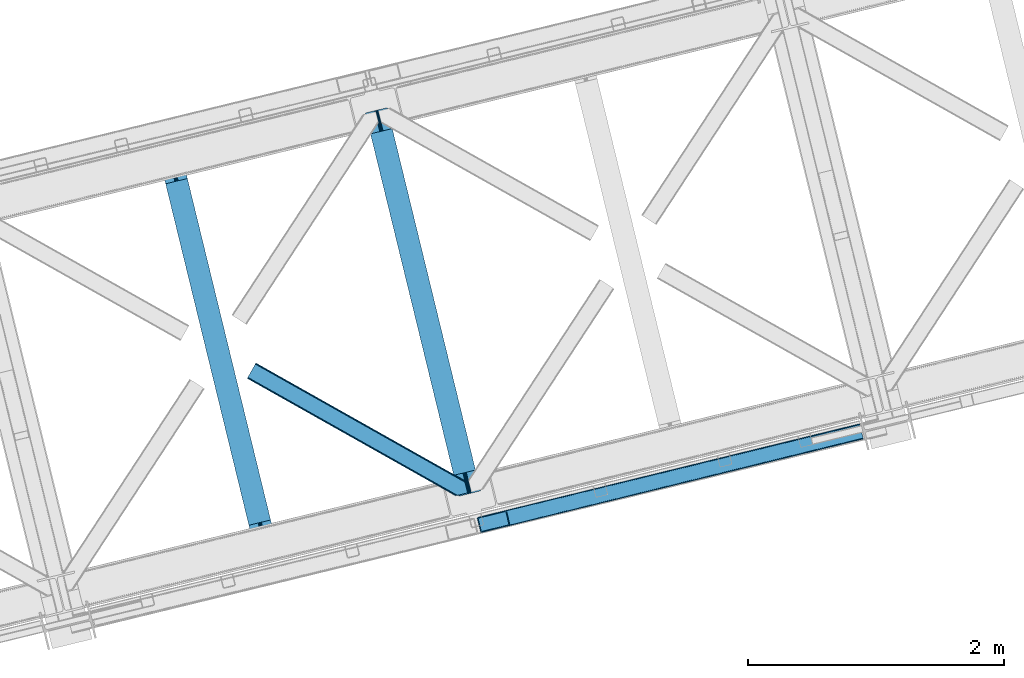
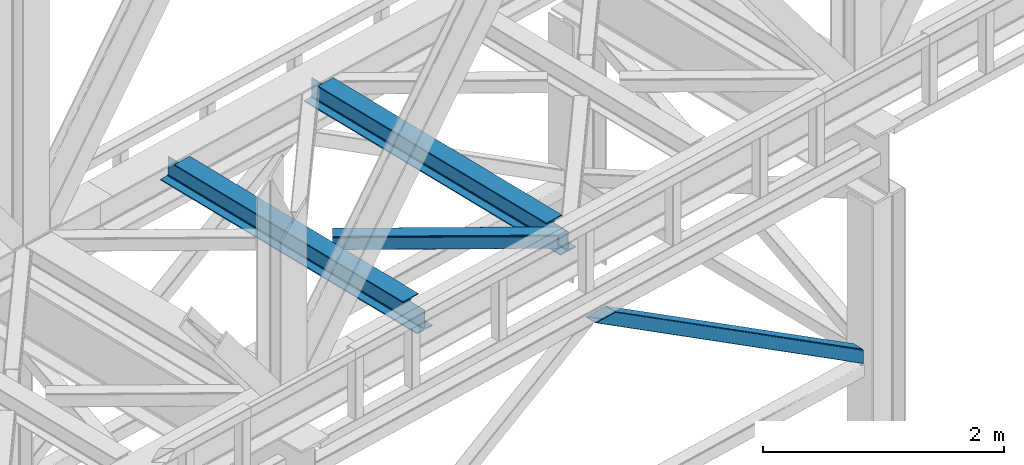
# One storey, part 47 of 92: 2 beams, 2 members.
"""IFC4 building model written with IfcOpenShell, lengths in millimetres."""

from ifc_helpers import new_model, entity, si_unit, converted_unit, derived_unit, direction, frame, origin, place, context, subcontext, project, spatial, triangles, polygons, material, type_object, element, save


model = new_model("IFC4")

# Units and contexts
model_context = context("Model", 3, precision=0.01, world=origin(), true_north=direction((6.12303176911189e-17, 1.0)))
plan_context = context("Plan", 3, precision=0.01, world=origin(), true_north=direction((6.12303176911189e-17, 1.0)))
body_context = subcontext(model_context, "Body", "Model", "MODEL_VIEW")
ifc_project = project(units=[si_unit("LENGTHUNIT", "METRE", prefix="MILLI"), si_unit("AREAUNIT", "SQUARE_METRE"), si_unit("VOLUMEUNIT", "CUBIC_METRE"), converted_unit("PLANEANGLEUNIT", "DEGREE", entity("IfcRatioMeasure", 0.0174532925199433), si_unit("PLANEANGLEUNIT", "RADIAN"), dimensions=[0, 0, 0, 0, 0, 0, 0]), si_unit("MASSUNIT", "GRAM", prefix="KILO"), derived_unit("MASSDENSITYUNIT", [(si_unit("MASSUNIT", "GRAM", prefix="KILO"), 1), (si_unit("LENGTHUNIT", "METRE"), -3)]), derived_unit("MOMENTOFINERTIAUNIT", [(si_unit("LENGTHUNIT", "METRE"), 4)]), si_unit("TIMEUNIT", "SECOND"), si_unit("FREQUENCYUNIT", "HERTZ"), si_unit("THERMODYNAMICTEMPERATUREUNIT", "DEGREE_CELSIUS"), derived_unit("THERMALTRANSMITTANCEUNIT", [(si_unit("MASSUNIT", "GRAM", prefix="KILO"), 1), (si_unit("THERMODYNAMICTEMPERATUREUNIT", "KELVIN"), -1), (si_unit("TIMEUNIT", "SECOND"), -3)]), derived_unit("VOLUMETRICFLOWRATEUNIT", [(si_unit("LENGTHUNIT", "METRE"), 3), (si_unit("TIMEUNIT", "SECOND"), -1)]), derived_unit("MASSFLOWRATEUNIT", [(si_unit("MASSUNIT", "GRAM", prefix="KILO"), 1), (si_unit("TIMEUNIT", "SECOND"), -1)]), derived_unit("ROTATIONALFREQUENCYUNIT", [(si_unit("TIMEUNIT", "SECOND"), -1)]), si_unit("ELECTRICCURRENTUNIT", "AMPERE"), si_unit("ELECTRICVOLTAGEUNIT", "VOLT"), si_unit("POWERUNIT", "WATT"), si_unit("FORCEUNIT", "NEWTON", prefix="KILO"), si_unit("ILLUMINANCEUNIT", "LUX"), si_unit("LUMINOUSFLUXUNIT", "LUMEN"), si_unit("LUMINOUSINTENSITYUNIT", "CANDELA"), derived_unit("USERDEFINED", [(si_unit("MASSUNIT", "GRAM", prefix="KILO"), -1), (si_unit("LENGTHUNIT", "METRE"), -2), (si_unit("TIMEUNIT", "SECOND"), 3), (si_unit("LUMINOUSFLUXUNIT", "LUMEN"), 1)]), derived_unit("LINEARVELOCITYUNIT", [(si_unit("LENGTHUNIT", "METRE"), 1), (si_unit("TIMEUNIT", "SECOND"), -1)]), si_unit("PRESSUREUNIT", "PASCAL"), derived_unit("USERDEFINED", [(si_unit("LENGTHUNIT", "METRE"), -2), (si_unit("MASSUNIT", "GRAM", prefix="KILO"), 1), (si_unit("TIMEUNIT", "SECOND"), -2)]), derived_unit("LINEARFORCEUNIT", [(si_unit("MASSUNIT", "GRAM", prefix="KILO"), 1), (si_unit("LENGTHUNIT", "METRE"), 1), (si_unit("TIMEUNIT", "SECOND"), -2), (si_unit("LENGTHUNIT", "METRE"), -1)]), derived_unit("PLANARFORCEUNIT", [(si_unit("MASSUNIT", "GRAM", prefix="KILO"), 1), (si_unit("LENGTHUNIT", "METRE"), 1), (si_unit("TIMEUNIT", "SECOND"), -2), (si_unit("LENGTHUNIT", "METRE"), -2)])], contexts=[model_context, plan_context])

# Site, building, storey
site_placement = place(None, origin())
site = spatial("IfcSite", under=ifc_project, at=site_placement, CompositionType="ELEMENT")
building_placement = place(site_placement, origin())
building = spatial("IfcBuilding", under=site, at=building_placement, CompositionType="ELEMENT")
storey_placement = place(building_placement, frame((0.0, 0.0, 15900.0)))
storey = spatial("IfcBuildingStorey", under=building, at=storey_placement, Name="05", CompositionType="ELEMENT", Elevation=15900.0)

# Beams
ifc_material = material(Name="Metal painted (White)")
beam_type = type_object("IfcBeamType", PredefinedType="BEAM")
beam_1_placement = place(storey_placement, frame((-41419.29, 7690.32, 3441.0)))
element("IfcBeam", 1, at=beam_1_placement, inside=storey, type_object=beam_type, material=ifc_material, ObjectType="Steel Beam", PredefinedType="BEAM", context=body_context, shape_type="Tessellation", body=[
    polygons([(900.98534618944, 41.4445662733081, 11.000000000004), (900.98534618944, 41.4445662733081, 2.16573425859679e-12), (170.021610174761, 3040.13999372697, 2.16573425859679e-12), (170.021610174761, 3040.13999372697, 11.000000000004), (834.919806235814, 25.3403919499645, 11.000000000004), (103.956070221135, 3024.03581940362, 11.000000000004), (828.971056214531, 23.8903211957396, 12.2179274798217), (98.0073201998513, 3022.5857486494, 12.2179274798217), (823.927949458422, 22.6610105689183, 15.6862915010192), (92.9642134437427, 3021.35643802258, 15.6862915010192), (820.558253255246, 21.8396114687108, 20.8770650821657), (89.5945172405668, 3020.53503892237, 20.8770650821657), (819.374973305552, 21.5511744621195, 27.0000000000047), (88.4112372908723, 3020.24660191578, 27.0000000000047), (81.6103728838888, 3018.58881926485, 27.0000000000047), (81.6103728838888, 3018.58881926485, 203.000000000006), (88.4112372908723, 3020.24660191578, 203.000000000006), (0.0, 2998.69542745366, 2.16573425859679e-12), (0.0, 2998.69542745366, 10.9999999999997), (66.0655399536259, 3014.799601777, 11.000000000004), (72.0142899749184, 3016.24967253123, 12.2179274798217), (77.057396731027, 3017.47898315805, 15.6862915010192), (80.4270929341942, 3018.30038225826, 20.8770650821613), (819.374973305543, 21.5511744621206, 203.000000000006), (812.574108898559, 19.8933918111876, 203.000000000006), (812.574108898559, 19.8933918111876, 27.0000000000047), (811.390828948873, 19.6049548045974, 20.8770650821613), (808.021132745689, 18.7835557043876, 15.6862915010192), (802.978025989589, 17.5542450775696, 12.2179274798217), (797.029275968296, 16.1041743233425, 11.000000000004), (730.963736014679, 0.0, 10.9999999999997), (730.963736014679, 0.0, 2.16573425859679e-12), (779.675212882749, 184.415062601693, 203.069791966819), (128.020401343512, 2857.75452019162, 203.000000000006), (128.243282132658, 2856.84017775719, 203.617301946336), (128.256196377177, 2856.7871977843, 217.000003693143), (779.530009633833, 185.010597404072, 217.000003676718), (779.530880241722, 185.007025963192, 204.00000679514), (772.96491171832, 182.385463974442, 203.006342981529), (772.742064056791, 183.299815969774, 203.617301946336), (772.729149812254, 183.352795942667, 217.000003693143), (121.455336555616, 2855.12939632289, 217.000003676718), (121.454465947718, 2855.13296776377, 204.00000679514), (121.310166358664, 2855.72494066435, 203.076120467494), (121.219536936511, 2856.09673754069, 203.000000000006), (780.713494357877, 185.298194377513, 223.122939328039), (784.082490766539, 186.122464201394, 228.313710402595), (789.125126170563, 187.353708426698, 231.782072735464), (795.073705041266, 188.804481281379, 232.999999602236), (861.13915590679, 204.909021065314, 232.999999283132), (861.137682570352, 204.915065042187, 243.999994005812), (691.116301666431, 163.469558245297, 243.999994827032), (691.117775002877, 163.463514268425, 233.000000104353), (757.183225868401, 179.568054052361, 232.999999785253), (763.132130996731, 181.017488520583, 231.782072861012), (768.175695503853, 182.244921343717, 228.313710479427), (771.546082413602, 183.063487001148, 223.12293937232), (120.271851831572, 2854.84179934945, 223.122939328039), (116.902855422901, 2854.01752952557, 228.313710402595), (111.860220018877, 2852.78628530027, 231.782072735464), (105.911641148165, 2851.33551244559, 232.999999602236), (39.8461902826505, 2835.23097266165, 232.999999283128), (39.8476636190881, 2835.22492868478, 243.999994005812), (209.869044523001, 2876.67043548167, 243.999994827032), (209.867571186572, 2876.67647945854, 233.000000104357), (143.802120321031, 2860.57193967461, 232.999999785253), (137.853215192718, 2859.12250520639, 231.782072861012), (132.809650685579, 2857.89507238325, 228.313710479427), (129.439263775847, 2857.07650672582, 223.12293937232)], [[[1, 2, 3, 4]], [[5, 1, 4, 6]], [[7, 5, 6, 8]], [[9, 7, 8, 10]], [[11, 9, 10, 12]], [[13, 11, 12, 14]], [[15, 16, 17, 14, 12, 10, 8, 6, 4, 3, 18, 19, 20, 21, 22, 23]], [[13, 24, 25, 26, 27, 28, 29, 30, 31, 32, 2, 1, 5, 7, 9, 11]], [[2, 32, 18, 3]], [[32, 31, 19, 18]], [[31, 30, 20, 19]], [[27, 26, 15, 23]], [[28, 27, 23, 22]], [[29, 28, 22, 21]], [[30, 29, 21, 20]], [[33, 24, 13, 14, 17, 34, 35, 36, 37, 38]], [[25, 39, 40, 41, 42, 43, 44, 16, 15, 26]], [[39, 25, 24, 33]], [[45, 34, 17, 16]], [[41, 40, 38, 37, 46, 47, 48, 49, 50, 51, 52, 53, 54, 55, 56, 57]], [[42, 58, 59, 60, 61, 62, 63, 64, 65, 66, 67, 68, 69, 36, 35, 43]], [[46, 37, 36, 69]], [[47, 46, 69, 68]], [[48, 47, 68, 67]], [[49, 48, 67, 66]], [[50, 49, 66, 65]], [[51, 50, 65, 64]], [[52, 51, 64, 63]], [[53, 52, 63, 62]], [[54, 53, 62, 61]], [[55, 54, 61, 60]], [[56, 55, 60, 59]], [[57, 56, 59, 58]], [[41, 57, 58, 42]]], closed=False),
])
beam_2_placement = place(storey_placement, frame((-39816.23, 8081.08, 3441.0)))
element("IfcBeam", 2, at=beam_2_placement, inside=storey, type_object=beam_type, material=ifc_material, ObjectType="Steel Beam", PredefinedType="BEAM", context=body_context, shape_type="Tessellation", body=[
    polygons([(900.98534618944, 41.4445662733081, 11.000000000004), (900.98534618944, 41.4445662733081, 2.16573425859679e-12), (170.02161017477, 3040.13999372697, 2.16573425859679e-12), (170.021610174761, 3040.13999372697, 11.000000000004), (834.919806235814, 25.3403919499656, 11.000000000004), (103.956070221135, 3024.03581940363, 11.000000000004), (828.971056214522, 23.8903211957385, 12.2179274798217), (98.0073201998427, 3022.5857486494, 12.2179274798217), (823.927949458418, 22.6610105689172, 15.6862915010192), (92.9642134437427, 3021.35643802258, 15.6862915010192), (820.558253255237, 21.8396114687097, 20.8770650821657), (89.5945172405581, 3020.53503892237, 20.8770650821657), (819.374973305552, 21.5511744621206, 27.0000000000047), (88.4112372908723, 3020.24660191578, 27.0000000000047), (81.6103728838888, 3018.58881926485, 27.0000000000047), (81.6103728838888, 3018.58881926485, 203.000000000006), (88.4112372908809, 3020.24660191578, 203.000000000006), (8.66293703438714e-12, 2998.69542745366, 2.16573425859679e-12), (8.66293703438714e-12, 2998.69542745366, 10.9999999999997), (66.0655399536259, 3014.799601777, 11.000000000004), (72.014289974927, 3016.24967253123, 12.2179274798217), (77.057396731027, 3017.47898315805, 15.6862915010192), (80.4270929342029, 3018.30038225826, 20.8770650821657), (819.374973305552, 21.5511744621206, 203.000000000006), (812.574108898564, 19.8933918111876, 203.000000000006), (812.574108898564, 19.8933918111876, 27.0000000000047), (811.390828948882, 19.6049548045974, 20.8770650821657), (808.021132745702, 18.7835557043898, 15.6862915010192), (802.978025989598, 17.5542450775685, 12.2179274798217), (797.029275968305, 16.1041743233425, 11.000000000004), (730.963736014688, 0.0, 10.9999999999997), (730.963736014688, 0.0, 2.16573425859679e-12), (779.675212882757, 184.415062601693, 203.069791966819), (128.020401343512, 2857.75452019162, 203.000000000006), (128.243282132658, 2856.84017775719, 203.617301946336), (128.256196377177, 2856.7871977843, 217.000003693143), (779.530009633833, 185.010597404072, 217.000003676718), (779.530880241722, 185.007025963192, 204.00000679514), (772.96491171832, 182.385463974442, 203.006342981529), (772.742064056782, 183.299815969774, 203.617301946336), (772.729149812263, 183.352795942667, 217.000003693143), (121.455336555608, 2855.1293963229, 217.000003676718), (121.454465947718, 2855.13296776378, 204.00000679514), (121.310166358664, 2855.72494066435, 203.076120467494), (121.21953693652, 2856.09673754069, 203.000000000006), (780.713494357868, 185.298194377513, 223.122939328039), (784.082490766539, 186.122464201392, 228.313710402595), (789.125126170563, 187.353708426696, 231.78207273546), (795.073705041266, 188.80448128138, 232.999999602236), (861.139155906794, 204.909021065314, 232.999999283132), (861.137682570357, 204.915065042187, 243.999994005812), (691.11630166644, 163.469558245297, 243.999994827032), (691.117775002877, 163.463514268423, 233.000000104353), (757.183225868401, 179.568054052359, 232.999999785253), (763.132130996739, 181.017488520583, 231.782072861012), (768.175695503862, 182.244921343715, 228.313710479427), (771.546082413611, 183.063487001148, 223.12293937232), (120.271851831572, 2854.84179934945, 223.122939328039), (116.902855422901, 2854.01752952557, 228.313710402595), (111.860220018886, 2852.78628530027, 231.782072735464), (105.911641148174, 2851.33551244559, 232.999999602236), (39.8461902826505, 2835.23097266165, 232.999999283128), (39.8476636190881, 2835.22492868478, 243.999994005812), (209.869044523001, 2876.67043548167, 243.999994827032), (209.867571186563, 2876.67647945854, 233.000000104357), (143.80212032104, 2860.57193967461, 232.999999785253), (137.85321519271, 2859.12250520638, 231.782072861007), (132.809650685579, 2857.89507238325, 228.313710479427), (129.439263775847, 2857.07650672582, 223.12293937232)], [[[1, 2, 3, 4]], [[5, 1, 4, 6]], [[7, 5, 6, 8]], [[9, 7, 8, 10]], [[11, 9, 10, 12]], [[13, 11, 12, 14]], [[15, 16, 17, 14, 12, 10, 8, 6, 4, 3, 18, 19, 20, 21, 22, 23]], [[13, 24, 25, 26, 27, 28, 29, 30, 31, 32, 2, 1, 5, 7, 9, 11]], [[2, 32, 18, 3]], [[32, 31, 19, 18]], [[31, 30, 20, 19]], [[27, 26, 15, 23]], [[28, 27, 23, 22]], [[29, 28, 22, 21]], [[30, 29, 21, 20]], [[33, 24, 13, 14, 17, 34, 35, 36, 37, 38]], [[25, 39, 40, 41, 42, 43, 44, 16, 15, 26]], [[39, 25, 24, 33]], [[45, 34, 17, 16]], [[41, 40, 38, 37, 46, 47, 48, 49, 50, 51, 52, 53, 54, 55, 56, 57]], [[42, 58, 59, 60, 61, 62, 63, 64, 65, 66, 67, 68, 69, 36, 35, 43]], [[46, 37, 36, 69]], [[47, 46, 69, 68]], [[48, 47, 68, 67]], [[49, 48, 67, 66]], [[50, 49, 66, 65]], [[51, 50, 65, 64]], [[52, 51, 64, 63]], [[53, 52, 63, 62]], [[54, 53, 62, 61]], [[55, 54, 61, 60]], [[56, 55, 60, 59]], [[57, 56, 59, 58]], [[41, 57, 58, 42]]], closed=False),
])

# Members
member_type_1 = type_object("IfcMemberType", PredefinedType="BRACE")
member_1_placement = place(storey_placement, frame((-38942.19, 7796.98, 965.73)))
element("IfcMember", 3, at=member_1_placement, inside=storey, type_object=member_type_1, ObjectType="Steel Vertical Brace", PredefinedType="BRACE", context=body_context, shape_type="Tessellation", body=[
    triangles([(2980.25064697266, 840.910299682618, 4.31950378417969), (3005.96535644531, 734.987113952638, 4.46135559082177), (0.0, 110.814166259765, 1902.27458496094), (25.9333007812456, 4.94446563720703, 1902.27458496094), (2993.26380615234, 851.573602294921, 0.777859497069585), (7.36001586914063, 120.226963806153, 1902.27458496094), (12.8666564941377, 122.203005981445, 1902.27458496094), (2986.92233276367, 848.369146728516, 1.96848449706886), (2993.30101318359, 851.416053771974, 0.0), (2.97888793945458, 117.368417358399, 1902.27458496094), (2993.08939819336, 852.292163085937, 4.33810729980542), (2981.60870361328, 844.395552062989, 3.70675048827979), (0.39532470703125, 114.063386535645, 1902.27458496094), (3022.51783447265, 731.559997558595, 0.863900756834482), (3022.69224243164, 730.848413085937, 4.42647399902489), (42.6090270996065, 0.792974853516171, 1902.27458496094), (36.8117065429688, 0.0, 1902.27458496094), (31.6073730468706, 0.510433959961119, 1902.27458496094), (3015.30432128906, 731.450701904297, 2.12545166015479), (3008.76518554687, 732.520985412598, 3.85674133300927), (27.7890014648438, 2.24695587158203, 1902.27458496094), (3022.48295288086, 731.707662963868, 0.126736450194585), (2993.08939819336, 852.292163085937, 132.50470275879), (214.121813964841, 171.505810546875, 1902.27458496094), (219.916809082031, 172.29878540039, 1902.27458496094), (2993.36612548828, 851.153860473633, 135.831243896486), (225.123468017577, 171.78835144043, 1902.27458496094), (2993.6428527832, 850.015557861328, 139.157785034178), (228.941839599611, 170.052410888672, 1902.27458496094), (2994.3125793457, 847.268051147462, 140.537933349609), (230.795214843747, 167.353738403321, 1902.27458496094), (2994.9823059082, 844.519963073731, 141.916918945313), (3020.79700927734, 738.620613098145, 141.994821166991), (256.730841064455, 61.484619140625, 1902.27458496094), (3021.46673583984, 735.872525024414, 140.619323730469), (3022.13646240234, 733.124436950683, 139.243826293947), (256.335516357423, 58.2353988647465, 1902.27458496094), (3022.41551513672, 731.986134338379, 135.918447875978), (253.749627685545, 54.9297866821289, 1902.27458496094), (3022.69224243164, 730.848413085937, 132.593069458009), (249.370825195314, 52.0724029541016, 1902.27458496094), (243.861859130855, 50.0957794189453, 1902.27458496094), (2994.85905761718, 840.371379089355, 0.32439880371021), (3018.68783569336, 742.221556091309, 0.455786132813955), (3020.39703369141, 740.26062927246, 0.11743469238354), (2995.40553588867, 842.7851852417, 0.00930175781104481), (8.33670043945313, 108.738130187989, 1902.27458496094), (32.3677917480454, 10.6388854980469, 1902.27458496094), (2994.7148803711, 845.623384094238, 3.0765563964851), (2994.18002929688, 847.814529418946, 5.44501647949073), (15.6967163085938, 118.150927734375, 1902.27458496094), (2995.25903320313, 843.389799499512, 0.662750244140625), (11.317913818355, 115.292381286621, 1902.27458496094), (8.73435058593896, 111.987350463867, 1902.27458496094), (2994.03585205078, 848.405772399902, 9.04363403320167), (21.2033569335908, 120.126969909668, 1902.27458496094), (34.2234924316363, 7.94137573242188, 1902.27458496094), (3020.55516357422, 739.609506225585, 0.589498901368643), (38.0395385742158, 6.20427246093732, 1902.27458496094), (3021.19000854492, 737.010827636718, 2.47426757812354), (43.2461975097613, 5.69441986083984, 1902.27458496094), (3021.46673583984, 735.872525024414, 5.80080871581958), (49.0435180664063, 6.48739471435601, 1902.27458496094), (3021.74346313476, 734.73422241211, 9.12734985351563), (2994.03585205078, 848.405772399902, 127.803826904295), (207.687322998048, 165.811390686035, 1902.27458496094), (2995.26135864258, 843.381660461427, 135.837057495119), (2995.93108520508, 840.633572387695, 137.216043090819), (224.360723876955, 161.659318542481, 1902.27458496094), (2994.59163208008, 846.129748535156, 134.456909179688), (222.507348632811, 164.357409667969, 1902.27458496094), (2994.3125793457, 847.268051147462, 131.130368041991), (218.688977050777, 166.09393157959, 1902.27458496094), (213.484643554686, 166.604946899414, 1902.27458496094), (247.996490478516, 60.3114349365233, 1902.27458496094), (248.391815185547, 63.5600738525391, 1902.27458496094), (235.525158691402, 52.1712341308594, 1902.27458496094), (245.412927246092, 57.0064041137693, 1902.27458496094), (241.034124755861, 54.1478576660156, 1902.27458496094), (3021.46673583984, 735.872525024414, 131.211758422851), (3021.74346313476, 734.73422241211, 127.887542724609), (3021.19000854492, 737.010827636718, 134.53713684082), (3020.52028198242, 739.758915710449, 135.912634277345), (3019.85055541992, 742.507003784181, 137.288131713867)], [[1, 2, 3], [4, 3, 2], [5, 6, 7], [6, 5, 8], [5, 9, 8], [8, 10, 6], [7, 11, 5], [8, 12, 10], [13, 10, 12], [12, 1, 13], [3, 13, 1], [14, 15, 16], [17, 18, 19], [19, 14, 17], [2, 20, 21], [21, 4, 2], [20, 19, 18], [18, 21, 20], [19, 22, 14], [16, 17, 14], [23, 11, 24], [7, 24, 11], [23, 24, 25], [26, 25, 27], [28, 27, 29], [30, 29, 31], [31, 32, 30], [29, 30, 28], [27, 28, 26], [25, 26, 23], [33, 32, 31], [31, 34, 33], [35, 33, 34], [36, 35, 37], [38, 36, 39], [40, 38, 41], [41, 42, 40], [39, 41, 38], [37, 39, 36], [34, 37, 35], [15, 40, 42], [42, 16, 15], [43, 44, 1], [45, 19, 44], [45, 22, 19], [46, 8, 9], [8, 46, 43], [43, 12, 8], [2, 44, 20], [20, 44, 19], [44, 2, 1], [43, 1, 12], [44, 43, 47], [47, 48, 44], [49, 50, 51], [52, 49, 53], [54, 47, 43], [43, 46, 54], [46, 52, 54], [53, 54, 52], [51, 53, 49], [50, 55, 56], [56, 51, 50], [57, 45, 44], [57, 58, 45], [45, 57, 59], [60, 59, 61], [62, 61, 63], [63, 64, 62], [61, 62, 60], [59, 60, 45], [44, 48, 57], [55, 65, 66], [66, 56, 55], [67, 68, 69], [70, 67, 71], [72, 70, 73], [65, 72, 74], [74, 66, 65], [73, 74, 72], [71, 73, 70], [69, 71, 67], [71, 27, 25], [69, 34, 31], [29, 71, 31], [71, 29, 27], [71, 69, 31], [73, 71, 25], [66, 24, 7], [24, 73, 25], [74, 24, 66], [74, 73, 24], [39, 75, 41], [76, 34, 69], [34, 75, 37], [75, 34, 76], [39, 37, 75], [42, 77, 16], [41, 75, 78], [78, 79, 42], [79, 77, 42], [42, 41, 78], [53, 6, 54], [7, 56, 66], [7, 51, 56], [53, 7, 6], [53, 51, 7], [47, 3, 4], [54, 6, 10], [13, 54, 10], [54, 13, 3], [47, 54, 3], [17, 59, 57], [16, 77, 63], [63, 61, 16], [61, 59, 16], [17, 16, 59], [18, 17, 57], [4, 48, 47], [57, 4, 21], [4, 57, 48], [21, 18, 57], [80, 40, 81], [15, 62, 64], [81, 40, 15], [22, 60, 15], [64, 81, 15], [62, 15, 60], [45, 60, 22], [80, 38, 40], [82, 35, 36], [38, 80, 82], [36, 38, 82], [83, 33, 35], [35, 82, 83], [33, 84, 32], [84, 33, 83], [65, 23, 72], [49, 9, 50], [52, 9, 49], [55, 23, 65], [11, 55, 50], [50, 9, 11], [55, 11, 23], [72, 26, 70], [67, 30, 32], [70, 30, 67], [68, 32, 84], [32, 68, 67], [70, 28, 30], [26, 72, 23], [26, 28, 70], [68, 84, 69], [76, 69, 84], [81, 77, 79], [80, 79, 78], [82, 78, 75], [83, 75, 76], [76, 84, 83], [75, 83, 82], [78, 82, 80], [79, 80, 81], [81, 64, 77], [63, 77, 64]]),
])
member_type_2 = type_object("IfcMemberType", PredefinedType="BRACE")
member_2_placement = place(storey_placement, frame((-40741.74, 8084.0, 3511.0)))
element("IfcMember", 4, at=member_2_placement, inside=storey, type_object=member_type_2, ObjectType="Steel Horizontal Brace", PredefinedType="BRACE", context=body_context, shape_type="Tessellation", body=[
    triangles([(1645.8111694336, 3.74570159912037, 138.667117309571), (1655.3361694336, 6.06765289306622, 139.999594116212), (8.58552246094041, 933.436628723144, 139.999594116212), (5.29735107422312, 927.60151977539, 138.667117309571), (1637.73724365234, 1.7772171020506, 134.874325561526), (2.511474609375, 922.654147338866, 134.874325561526), (1632.34222412109, 0.462181091308594, 129.197927856447), (0.651123046875, 919.349116516112, 129.197927856447), (1630.44466552735, 0.0, 122.500662231447), (0.0, 918.188722229004, 122.500662231447), (1630.44466552735, 0.0, 17.5000946044929), (0.0, 918.188722229004, 17.5000946044929), (1706.56560058594, 97.7219421386717, 139.999594116212), (1724.78309326172, 22.9956893920898, 139.999594116212), (60.1079589843794, 1024.92639312744, 139.999594116212), (1701.3240600586, 119.229931640624, 129.197927856447), (1700.89152832032, 121.001916503907, 122.500662231447), (68.0423583984375, 1039.01448669434, 129.197927856447), (68.6934814453125, 1040.17488098145, 122.500662231447), (1702.55654296876, 114.183146667479, 134.874325561526), (66.1773559570356, 1035.70887451172, 134.874325561526), (1704.39829101563, 106.630700683593, 138.667117309571), (63.3961303710967, 1030.76208343506, 138.667117309571), (1700.89152832032, 121.001916503907, 17.5000946044929), (68.6934814453125, 1040.17488098145, 17.5000946044929), (0.651123046875, 919.349116516112, 10.8028289794929), (1633.02590332032, 0.628450012206486, 10.9377044677749), (2.511474609375, 922.654147338866, 5.12526855468968), (5.29735107422312, 927.60151977539, 1.33247680664135), (1569.79720458985, 46.5552978515625, 1.33247680664135), (1573.68999023438, 34.810665893554, 8.52041015625218), (1571.51337890625, 39.5190994262693, 5.59500732422021), (1572.28542480469, 36.3408050537109, 7.52047119140843), (1573.34582519531, 35.1809921264648, 8.278564453125), (1572.98770751953, 35.5757354736324, 8.02044067383031), (1572.62493896484, 35.9698974609373, 7.76231689453198), (1633.97468261719, 0.859831237792605, 8.52041015625218), (1567.62524414063, 55.464056396484, 0.0), (8.58552246094041, 933.436628723144, 0.0), (1533.57615966797, 195.143321228026, 0.0), (60.1079589843794, 1024.92639312744, 0.0), (1566.72762451172, 59.1423202514643, 7.52047119140843), (1567.24387207031, 57.3435928344725, 7.90300598144677), (1567.77872314453, 56.4360900878901, 8.1076446533225), (1568.32287597656, 55.5210296630858, 8.31460876464917), (1568.41124267579, 55.3774337768555, 8.3471649169951), (1568.86237792969, 54.6135269165034, 8.52041015625218), (1655.14548339844, 6.02114410400372, 8.52041015625218), (5.94847412109812, 928.753775024414, 12.1260040283232), (1647.69477539063, 4.20439453124982, 12.1260040283232), (8.73435058593896, 933.700566101073, 8.3320495605476), (12.0178710937544, 939.535675048828, 6.99957275390625), (1565.35561523438, 64.7762786865233, 6.99957275390625), (1642.29975585938, 2.88935852050781, 17.8035644531265), (4.08812255859812, 925.448162841796, 17.8035644531265), (1640.40219726563, 2.42717742919922, 24.4996673583992), (3.43234863281396, 924.287768554686, 24.4996673583992), (1640.40219726563, 2.42717742919922, 115.501089477541), (3.43234863281396, 924.287768554686, 115.501089477541), (1647.69477539063, 4.20439453124982, 127.87475280762), (1655.76870117188, 6.17287902831958, 131.667544555665), (1642.29975585938, 2.88935852050781, 122.196029663086), (1665.29370117188, 8.49483032226544, 133.000021362306), (1724.78309326172, 22.9956893920898, 133.000021362306), (4.08812255859812, 925.448162841796, 122.196029663086), (5.94847412109812, 928.753775024414, 127.87475280762), (8.73435058593896, 933.700566101073, 131.667544555665), (12.0178710937544, 939.535675048828, 133.000021362306), (1708.8398803711, 88.4097198486324, 133.000021362306), (56.6709594726563, 1018.82734680176, 133.000021362306), (1535.84578857422, 185.831680297852, 6.99957275390625), (56.6709594726563, 1018.82734680176, 6.99957275390625), (68.0423583984375, 1039.01448669434, 10.8028289794929), (62.7450073242217, 1029.60924682617, 12.1260040283232), (64.6053588867217, 1032.91485900879, 17.8035644531265), (65.2611328125058, 1034.07583465576, 24.4996673583992), (66.1773559570356, 1035.70887451172, 5.12526855468968), (63.3961303710967, 1030.76208343506, 1.33247680664135), (59.9591308593808, 1024.66245574951, 8.3320495605476), (62.7450073242217, 1029.60924682617, 127.87475280762), (65.2611328125058, 1034.07583465576, 115.501089477541), (64.6053588867217, 1032.91485900879, 122.196029663086), (59.9591308593808, 1024.66245574951, 131.667544555665), (1703.16115722657, 111.689694213866, 24.4996673583992), (1703.16115722657, 111.689694213866, 115.501089477541), (1706.66791992188, 97.3190597534176, 131.667544555665), (1704.826171875, 104.871505737305, 127.87475280762), (1703.59368896484, 109.917709350586, 122.196029663086), (1704.826171875, 104.871505737305, 12.1260040283232), (1706.52374267578, 97.9004196166989, 8.52041015625218), (1701.6961303711, 117.703280639647, 8.52041015625218), (1703.59368896484, 109.917709350586, 17.8035644531265), (1701.48218994141, 118.591017150879, 10.9365417480476), (1534.47377929688, 191.465638732911, 7.52047119140843), (1529.68802490235, 211.088859558105, 5.59500732422021), (1528.91597900391, 214.266572570801, 7.52047119140843), (1531.40419921876, 204.05207977295, 1.33247680664135), (1529.11131591797, 214.689802551269, 8.22740478515698), (1529.01364746094, 214.478187561035, 7.87393798828271), (1529.89731445313, 214.453189086913, 8.52041015625218), (1534.34820556641, 192.706260681152, 7.85649719238427), (1534.72492675782, 194.650328063964, 8.52041015625218)], [[1, 2, 3], [3, 4, 1], [5, 1, 4], [4, 6, 5], [7, 5, 6], [6, 8, 7], [9, 7, 8], [8, 10, 9], [11, 9, 10], [10, 12, 11], [2, 13, 3], [2, 14, 13], [15, 3, 13], [16, 17, 18], [19, 18, 17], [20, 16, 21], [18, 21, 16], [22, 20, 23], [21, 23, 20], [13, 22, 15], [23, 15, 22], [17, 24, 19], [25, 19, 24], [26, 27, 11], [28, 29, 30], [27, 26, 31], [26, 28, 32], [32, 33, 26], [34, 26, 35], [34, 31, 26], [26, 36, 35], [26, 33, 36], [31, 37, 27], [30, 32, 28], [38, 30, 29], [29, 39, 38], [11, 12, 26], [40, 38, 39], [39, 41, 40], [33, 42, 43], [36, 43, 44], [35, 44, 45], [34, 46, 47], [34, 45, 46], [47, 31, 34], [45, 34, 35], [44, 35, 36], [43, 36, 33], [48, 37, 47], [31, 47, 37], [49, 50, 47], [47, 51, 49], [47, 46, 51], [50, 48, 47], [52, 43, 42], [51, 46, 45], [45, 52, 51], [45, 44, 52], [43, 52, 44], [42, 53, 52], [54, 50, 49], [49, 55, 54], [56, 54, 55], [55, 57, 56], [58, 56, 57], [57, 59, 58], [60, 61, 1], [5, 60, 1], [5, 7, 62], [60, 5, 62], [62, 7, 9], [61, 2, 1], [14, 63, 64], [14, 2, 63], [61, 63, 2], [62, 9, 58], [56, 11, 54], [9, 56, 58], [11, 27, 54], [9, 11, 56], [37, 54, 27], [50, 54, 37], [48, 50, 37], [62, 58, 65], [59, 65, 58], [60, 62, 66], [65, 66, 62], [61, 60, 67], [66, 67, 60], [63, 61, 68], [67, 68, 61], [69, 63, 68], [63, 69, 64], [68, 70, 69], [53, 71, 52], [72, 52, 71], [73, 74, 75], [76, 19, 25], [73, 75, 25], [73, 77, 74], [75, 76, 25], [74, 77, 78], [72, 41, 39], [41, 79, 78], [79, 41, 72], [79, 74, 78], [18, 80, 21], [81, 19, 76], [19, 82, 18], [82, 19, 81], [18, 82, 80], [15, 70, 3], [23, 21, 80], [80, 83, 23], [83, 70, 15], [15, 23, 83], [49, 29, 28], [39, 52, 72], [39, 51, 52], [51, 39, 29], [49, 51, 29], [57, 12, 10], [26, 55, 49], [28, 26, 49], [55, 26, 12], [57, 55, 12], [4, 66, 6], [3, 70, 68], [68, 67, 3], [67, 66, 4], [4, 3, 67], [8, 6, 66], [10, 59, 57], [65, 10, 8], [10, 65, 59], [65, 8, 66], [84, 85, 76], [81, 76, 85], [86, 69, 70], [70, 83, 86], [87, 86, 83], [83, 80, 87], [88, 87, 80], [80, 82, 88], [85, 88, 82], [82, 81, 85], [87, 20, 22], [89, 90, 91], [20, 87, 88], [86, 87, 22], [86, 13, 69], [14, 69, 13], [69, 14, 64], [86, 22, 13], [24, 17, 84], [91, 92, 89], [92, 24, 84], [93, 92, 91], [93, 24, 92], [17, 85, 84], [88, 16, 20], [17, 16, 88], [85, 17, 88], [40, 71, 53], [94, 95, 96], [40, 94, 71], [94, 97, 95], [94, 40, 97], [38, 40, 53], [42, 38, 53], [32, 42, 33], [42, 30, 38], [42, 32, 30], [73, 25, 24], [98, 99, 77], [96, 77, 99], [96, 95, 77], [73, 93, 100], [100, 77, 73], [100, 98, 77], [93, 91, 100], [78, 77, 95], [97, 40, 41], [41, 78, 97], [95, 97, 78], [24, 93, 73], [72, 71, 94], [94, 79, 72], [101, 102, 79], [79, 94, 101], [74, 79, 102], [90, 89, 102], [74, 102, 89], [92, 84, 75], [76, 75, 84], [89, 92, 74], [75, 74, 92], [101, 94, 99], [102, 101, 99], [91, 90, 102], [102, 100, 91]]),
])

save(model, "model.ifc")
